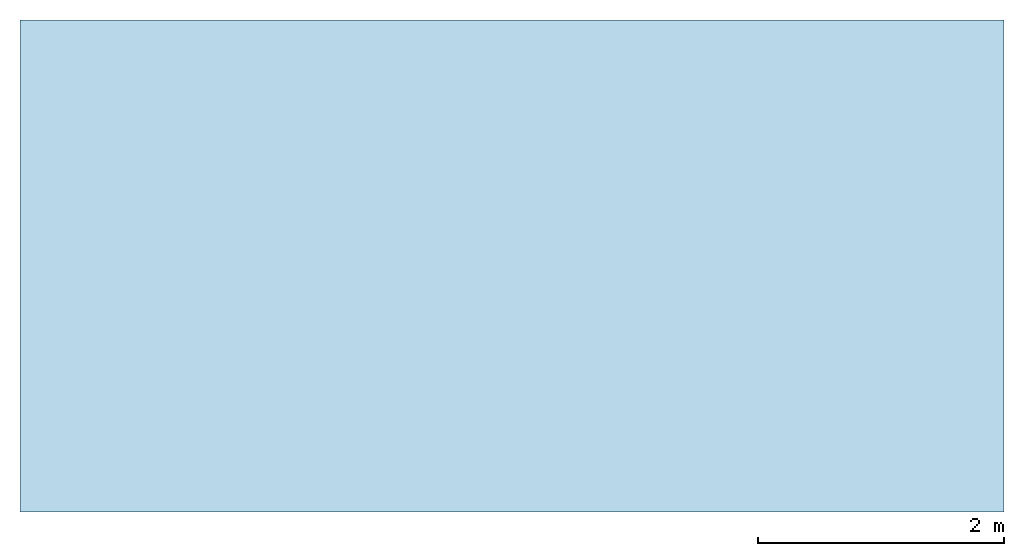
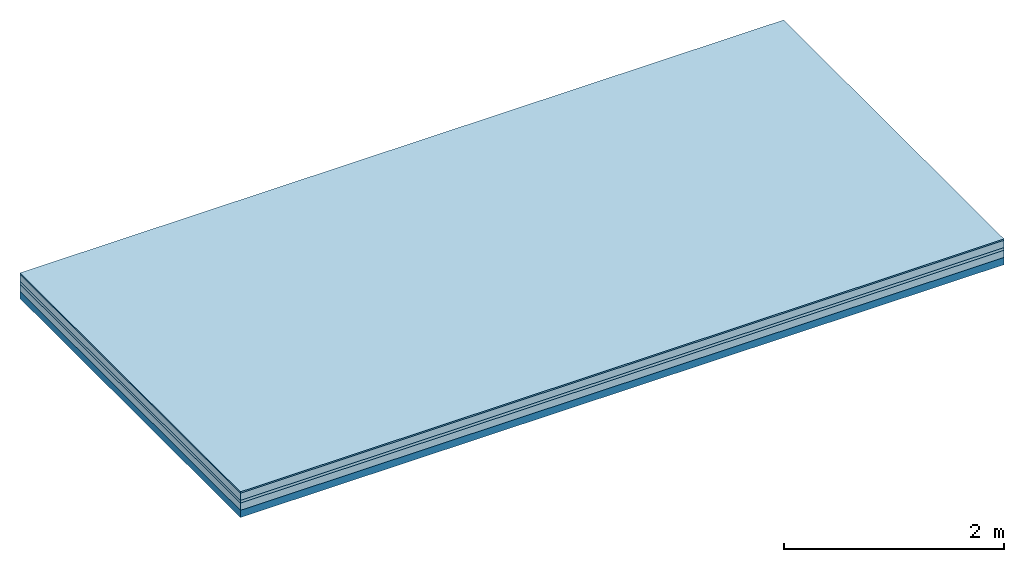
# One storey: 4 plates, 1 member, 1 element without a shape of its own.
"""IFC4 building model written with IfcOpenShell, lengths in metres."""

import ifcopenshell
import ifcopenshell.guid

model = None  # the IFC model being written
_history = None  # IfcOwnerHistory: only IFC2X3 demands one
_inside = {}  # id of a spatial element -> (the spatial element, [elements in it])
_under = {}  # id of a project, library or spatial element -> (it, [spatial elements below it])
_declared = {}  # id of a project -> (the project, [libraries it declares])
_typed = {}  # id of a type object -> (the type object, [elements of that type])
_made_of = {}  # id of a material, layer set ... -> (it, [elements and type objects made of it])


def new_model(schema):
    """Start an empty IFC model of exactly this schema.

    Asked for "IFC4X3", IfcOpenShell would pick the latest addendum, in which some entities
    have other attributes; the version numbers below select the first issue.
    IFC2X3 requires an IfcOwnerHistory on every rooted entity: one is made here for all.
    """
    global model, _history
    if schema == "IFC4X3":
        model = ifcopenshell.file(schema_version=(4, 3, 0, 0))
    else:
        model = ifcopenshell.file(schema=schema)
    _inside.clear()
    _under.clear()
    _declared.clear()
    _typed.clear()
    _made_of.clear()
    _history = None
    if model.schema == "IFC2X3":
        org = make("IfcOrganization", Name="unknown")
        user = make(
            "IfcPersonAndOrganization",
            ThePerson=make("IfcPerson", FamilyName="unknown"),
            TheOrganization=org,
        )
        app = make(
            "IfcApplication",
            ApplicationDeveloper=org,
            Version="unknown",
            ApplicationFullName="unknown",
            ApplicationIdentifier="unknown",
        )
        _history = make(
            "IfcOwnerHistory",
            OwningUser=user,
            OwningApplication=app,
            ChangeAction="ADDED",
            CreationDate=0,
        )
    return model


def make(cls, **values):
    """One entity of the class cls with the attributes given. An attribute that is None is left unset."""
    return model.create_entity(
        cls, **{name: value for name, value in values.items() if value is not None}
    )


def rooted(cls, **values):
    """An entity with a GlobalId (a new one), such as an element, a storey or a relation."""
    return make(cls, GlobalId=ifcopenshell.guid.new(), OwnerHistory=_history, **values)


def si_unit(unit_type, name, prefix=None):
    """IfcSIUnit, for example si_unit("LENGTHUNIT", "METRE", prefix="MILLI")."""
    return make("IfcSIUnit", UnitType=unit_type, Prefix=prefix, Name=name)


def derived_unit(unit_type, elements):
    """IfcDerivedUnit: a product of units, each with its exponent."""
    return make(
        "IfcDerivedUnit",
        Elements=[
            make("IfcDerivedUnitElement", Unit=unit, Exponent=power)
            for unit, power in elements
        ],
        UnitType=unit_type,
    )


def assignment(units):
    """IfcUnitAssignment: the units of a project."""
    return None if units is None else make("IfcUnitAssignment", Units=units)


def point(xyz):
    """IfcCartesianPoint."""
    return None if xyz is None else make("IfcCartesianPoint", Coordinates=xyz)


def direction(xyz):
    """IfcDirection."""
    return None if xyz is None else make("IfcDirection", DirectionRatios=xyz)


def frame(location, z_axis=None, x_axis=None):
    """IfcAxis2Placement3D, a coordinate frame: its origin and axes. An axis left out is left unset."""
    return make(
        "IfcAxis2Placement3D",
        Location=point(location),
        Axis=direction(z_axis),
        RefDirection=direction(x_axis),
    )


def frame_2d(location, x_axis=None):
    """IfcAxis2Placement2D, a coordinate frame in the plane: its origin and x axis."""
    return make(
        "IfcAxis2Placement2D", Location=point(location), RefDirection=direction(x_axis)
    )


def origin():
    """The frame at (0, 0, 0) with its axes left unset."""
    return frame((0.0, 0.0, 0.0))


def origin_with_axes():
    """The frame at (0, 0, 0) with the z axis (0, 0, 1) and the x axis (1, 0, 0) written out."""
    return frame((0.0, 0.0, 0.0), z_axis=(0.0, 0.0, 1.0), x_axis=(1.0, 0.0, 0.0))


def place(relative_to, where):
    """IfcLocalPlacement: puts the frame where relative to a parent placement (None: the world)."""
    return make(
        "IfcLocalPlacement", PlacementRelTo=relative_to, RelativePlacement=where
    )


def context(
    kind, dimensions, precision=None, world=None, true_north=None, identifier=None
):
    """IfcGeometricRepresentationContext, for example the 3D "Model" context."""
    return make(
        "IfcGeometricRepresentationContext",
        ContextIdentifier=identifier,
        ContextType=kind,
        CoordinateSpaceDimension=dimensions,
        Precision=precision,
        WorldCoordinateSystem=world,
        TrueNorth=true_north,
    )


def project(units=None, contexts=None):
    """IfcProject with its units and contexts."""
    return rooted(
        "IfcProject",
        Name="project",
        RepresentationContexts=contexts,
        UnitsInContext=assignment(units),
    )


def spatial(cls, under=None, at=None, **own):
    """A site, building, storey or space (cls), placed at a placement, below another one or the project."""
    s = rooted(cls, ObjectPlacement=at, **own)
    if under is not None:
        _under.setdefault(under.id(), (under, []))[1].append(s)
    return s


def profile(cls, at=None, kind="AREA", **sizes):
    """A parametric profile (cls). Its sizes go by their IFC names, for example OverallWidth=200.0."""
    return make(cls, ProfileType=kind, Position=at, **sizes)


def rectangle(**sizes):
    """IfcRectangleProfileDef."""
    return profile("IfcRectangleProfileDef", **sizes)


def extrude(swept, where, along, depth):
    """IfcExtrudedAreaSolid: the profile swept, set in the frame where, extruded along a direction by depth."""
    return make(
        "IfcExtrudedAreaSolid",
        SweptArea=swept,
        Position=where,
        ExtrudedDirection=direction(along),
        Depth=depth,
    )


def shape(context_of_items, identifier, shape_type, items):
    """IfcShapeRepresentation: the items that make up one representation, for example the "Body"."""
    return make(
        "IfcShapeRepresentation",
        ContextOfItems=context_of_items,
        RepresentationIdentifier=identifier,
        RepresentationType=shape_type,
        Items=items,
    )


def material(Name=None, Category=None):
    """IfcMaterial."""
    return make("IfcMaterial", Name=Name, Category=Category)


def layer(
    of_material, thickness, ventilated=None, Name=None, Category=None, Priority=None
):
    """IfcMaterialLayer: one layer of a wall or slab, of a material (None: an air gap)."""
    return make(
        "IfcMaterialLayer",
        Material=of_material,
        LayerThickness=thickness,
        IsVentilated=ventilated,
        Name=Name,
        Category=Category,
        Priority=Priority,
    )


def layer_set(layers, Name=None):
    """IfcMaterialLayerSet."""
    return make("IfcMaterialLayerSet", MaterialLayers=layers, LayerSetName=Name)


def made_of(thing, what):
    """Note that an element or type object is made of a material, layer set ...; save() writes the relation."""
    if what is not None:
        _made_of.setdefault(what.id(), (what, []))[1].append(thing)
    return thing


def type_object(cls, material=None, **own):
    """A type object (cls), such as IfcWallType, which elements share."""
    return made_of(rooted(cls, **own), material)


def element(
    cls,
    number,
    at=None,
    inside=None,
    cuts=None,
    type_object=None,
    material=None,
    context=None,
    identifier="Body",
    shape_type=None,
    held_by="IfcProductDefinitionShape",
    body=None,
    shapes=None,
    **own,
):
    """One element of the class cls, such as IfcWall. Its Tag is "e" and its number.

    at: its placement. inside: the storey or other place that contains it. cuts: it is an
    opening in that element (IfcRelVoidsElement). A single representation is given by context,
    identifier, shape_type and body (its items); several are given by shapes. held_by: the class
    of the entity that holds the representations. save() writes the other relations.
    """
    e = rooted(cls, Tag="e%d" % number, ObjectPlacement=at, **own)
    if body is not None:
        shapes = [shape(context, identifier, shape_type, body)]
    if shapes is not None:
        e.Representation = make(held_by, Representations=shapes)
    if inside is not None:
        _inside.setdefault(inside.id(), (inside, []))[1].append(e)
    if cuts is not None:
        rooted(
            "IfcRelVoidsElement", RelatingBuildingElement=cuts, RelatedOpeningElement=e
        )
    if type_object is not None:
        _typed.setdefault(type_object.id(), (type_object, []))[1].append(e)
    return made_of(e, material)


def aggregate(whole, parts):
    """IfcRelAggregates: a whole, such as a stair, and the parts it consists of."""
    return rooted("IfcRelAggregates", RelatingObject=whole, RelatedObjects=parts)


def save(model, path):
    """Write the relations noted so far, then the file.

    IfcRelAggregates (storeys below a building ...), IfcRelContainedInSpatialStructure (elements
    in a storey), IfcRelDefinesByType, IfcRelAssociatesMaterial and IfcRelDeclares: one each for
    every whole, place, type object, material and project.
    """
    for whole, parts in _under.values():
        aggregate(whole, parts)
    for where, things in _inside.values():
        rooted(
            "IfcRelContainedInSpatialStructure",
            RelatedElements=things,
            RelatingStructure=where,
        )
    for kind, things in _typed.values():
        rooted("IfcRelDefinesByType", RelatedObjects=things, RelatingType=kind)
    for what, things in _made_of.values():
        rooted("IfcRelAssociatesMaterial", RelatedObjects=things, RelatingMaterial=what)
    for by, libraries in _declared.values():
        rooted("IfcRelDeclares", RelatingContext=by, RelatedDefinitions=libraries)
    model.write(path)


model = new_model("IFC4")

# Units and contexts
plan_context = context("Plan", 3, precision=1e-05, world=origin(), true_north=direction((0.0, 1.0)))
model_context = context("Model", 3, precision=1e-05, world=origin(), true_north=direction((0.0, 1.0)))
ifc_project = project(units=[si_unit("LENGTHUNIT", "METRE"), derived_unit("SOUNDPRESSUREUNIT", [(si_unit("PRESSUREUNIT", "PASCAL", prefix="MICRO"), 0)]), si_unit("ENERGYUNIT", "JOULE", prefix="MEGA"), si_unit("MASSUNIT", "GRAM", prefix="KILO"), derived_unit("THERMALTRANSMITTANCEUNIT", [(si_unit("POWERUNIT", "WATT"), 1), (si_unit("AREAUNIT", "SQUARE_METRE"), -1), (si_unit("THERMODYNAMICTEMPERATUREUNIT", "KELVIN"), -1)]), derived_unit("AREADENSITYUNIT", [(si_unit("MASSUNIT", "GRAM", prefix="KILO"), 1), (si_unit("AREAUNIT", "SQUARE_METRE"), -1)]), derived_unit("USERDEFINED", [(si_unit("ENERGYUNIT", "JOULE", prefix="MEGA"), 1), (si_unit("AREAUNIT", "SQUARE_METRE"), -1)])], contexts=[plan_context, model_context])

# Site, building, storey
site = spatial("IfcSite", under=ifc_project)
building_placement = place(None, origin())
building = spatial("IfcBuilding", under=site, at=building_placement)
storey_placement = place(building_placement, origin())
storey = spatial("IfcBuildingStorey", under=building, at=storey_placement)

# Slab, member, plates
ifc_material_1 = material(Category="11.013")
ifc_layer_1 = layer(ifc_material_1, 0.015, Name="Flooring")
ifc_material_2 = material(Name="Cement screed", Category="04.006")
ifc_layer_2 = layer(ifc_material_2, 0.08, Name="On-material")
ifc_material_3 = material(Name="Wood fiber generic product", Category="10.009")
ifc_layer_3 = layer(ifc_material_3, 0.03, Name="Impact sound insulation")
ifc_material_4 = material(Category="01.002")
ifc_layer_4 = layer(ifc_material_4, 0.08, Name="Sub-floor")
ifc_material_5 = material(Name="Rigid, of the art")
ifc_layer_5 = layer(ifc_material_5, 0.0, Name="Bond")
ifc_layer_6 = layer(None, 0.08, Name="Supporting structure")
ifc_layer_set = layer_set([ifc_layer_1, ifc_layer_2, ifc_layer_3, ifc_layer_4, ifc_layer_5, ifc_layer_6])
slab_type = type_object("IfcSlabType", Name="A2207", PredefinedType="NOTDEFINED", material=ifc_layer_set)
slab_placement = place(None, frame((0.0, 0.0, 0.0), z_axis=(0.0, 0.0, -1.0), x_axis=(1.0, 0.0, 0.0)))
slab = element("IfcSlab", 1, at=slab_placement, inside=storey, type_object=slab_type, material=ifc_layer_set, Name="Slab #1")
ifc_material_6 = material(Name="Solid timber panel")
member_placement = place(slab_placement, origin())
member = element("IfcMember", 2, at=member_placement, material=ifc_material_6, Name="Supporting structure", context=plan_context, shape_type="SweptSolid", body=[
    extrude(rectangle(XDim=1.0, YDim=0.08, at=frame_2d((0.5, 0.04), x_axis=(1.0, 0.0))), frame((0.0, 4.0, 0.205), z_axis=(0.0, -1.0, 0.0), x_axis=(1.0, 0.0, 0.0)), (0.0, 0.0, 1.0), 4.0),
    extrude(rectangle(XDim=1.0, YDim=0.08, at=frame_2d((0.5, 0.04), x_axis=(1.0, 0.0))), frame((1.0, 4.0, 0.205), z_axis=(0.0, -1.0, 0.0), x_axis=(1.0, 0.0, 0.0)), (0.0, 0.0, 1.0), 4.0),
    extrude(rectangle(XDim=1.0, YDim=0.08, at=frame_2d((0.5, 0.04), x_axis=(1.0, 0.0))), frame((2.0, 4.0, 0.205), z_axis=(0.0, -1.0, 0.0), x_axis=(1.0, 0.0, 0.0)), (0.0, 0.0, 1.0), 4.0),
    extrude(rectangle(XDim=1.0, YDim=0.08, at=frame_2d((0.5, 0.04), x_axis=(1.0, 0.0))), frame((3.0, 4.0, 0.205), z_axis=(0.0, -1.0, 0.0), x_axis=(1.0, 0.0, 0.0)), (0.0, 0.0, 1.0), 4.0),
    extrude(rectangle(XDim=1.0, YDim=0.08, at=frame_2d((0.5, 0.04), x_axis=(1.0, 0.0))), frame((4.0, 4.0, 0.205), z_axis=(0.0, -1.0, 0.0), x_axis=(1.0, 0.0, 0.0)), (0.0, 0.0, 1.0), 4.0),
    extrude(rectangle(XDim=1.0, YDim=0.08, at=frame_2d((0.5, 0.04), x_axis=(1.0, 0.0))), frame((5.0, 4.0, 0.205), z_axis=(0.0, -1.0, 0.0), x_axis=(1.0, 0.0, 0.0)), (0.0, 0.0, 1.0), 4.0),
    extrude(rectangle(XDim=1.0, YDim=0.08, at=frame_2d((0.5, 0.04), x_axis=(1.0, 0.0))), frame((6.0, 4.0, 0.205), z_axis=(0.0, -1.0, 0.0), x_axis=(1.0, 0.0, 0.0)), (0.0, 0.0, 1.0), 4.0),
    extrude(rectangle(XDim=1.0, YDim=0.08, at=frame_2d((0.5, 0.04), x_axis=(1.0, 0.0))), frame((7.0, 4.0, 0.205), z_axis=(0.0, -1.0, 0.0), x_axis=(1.0, 0.0, 0.0)), (0.0, 0.0, 1.0), 4.0),
])
plate_1_placement = place(slab_placement, origin())
plate_1 = element("IfcPlate", 3, at=plate_1_placement, material=ifc_material_1, Name="Flooring", context=plan_context, shape_type="SweptSolid", body=[
    extrude(rectangle(XDim=8.0, YDim=4.0, at=frame_2d((4.0, 2.0), x_axis=(1.0, 0.0))), origin_with_axes(), (0.0, 0.0, 1.0), 0.015),
])
plate_2_placement = place(slab_placement, origin())
plate_2 = element("IfcPlate", 4, at=plate_2_placement, material=ifc_material_2, Name="On-material", context=plan_context, shape_type="SweptSolid", body=[
    extrude(rectangle(XDim=8.0, YDim=4.0, at=frame_2d((4.0, 2.0), x_axis=(1.0, 0.0))), frame((0.0, 0.0, 0.015), z_axis=(0.0, 0.0, 1.0), x_axis=(1.0, 0.0, 0.0)), (0.0, 0.0, 1.0), 0.08),
])
plate_3_placement = place(slab_placement, origin())
plate_3 = element("IfcPlate", 5, at=plate_3_placement, material=ifc_material_3, Name="Impact sound insulation", context=plan_context, shape_type="SweptSolid", body=[
    extrude(rectangle(XDim=8.0, YDim=4.0, at=frame_2d((4.0, 2.0), x_axis=(1.0, 0.0))), frame((0.0, 0.0, 0.095), z_axis=(0.0, 0.0, 1.0), x_axis=(1.0, 0.0, 0.0)), (0.0, 0.0, 1.0), 0.03),
])
plate_4_placement = place(slab_placement, origin())
plate_4 = element("IfcPlate", 6, at=plate_4_placement, material=ifc_material_4, Name="Sub-floor", context=plan_context, shape_type="SweptSolid", body=[
    extrude(rectangle(XDim=8.0, YDim=4.0, at=frame_2d((4.0, 2.0), x_axis=(1.0, 0.0))), frame((0.0, 0.0, 0.125), z_axis=(0.0, 0.0, 1.0), x_axis=(1.0, 0.0, 0.0)), (0.0, 0.0, 1.0), 0.08),
])
aggregate(slab, [plate_1, plate_2, plate_3, plate_4, member])

save(model, "model.ifc")
